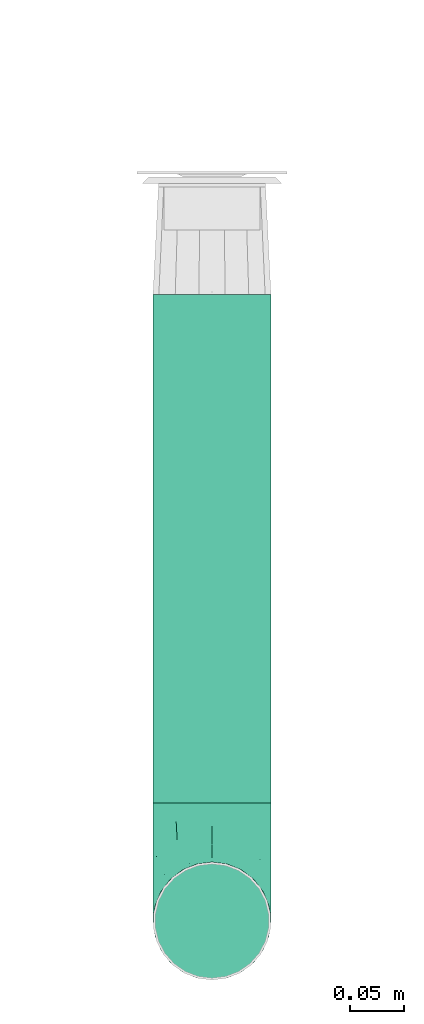
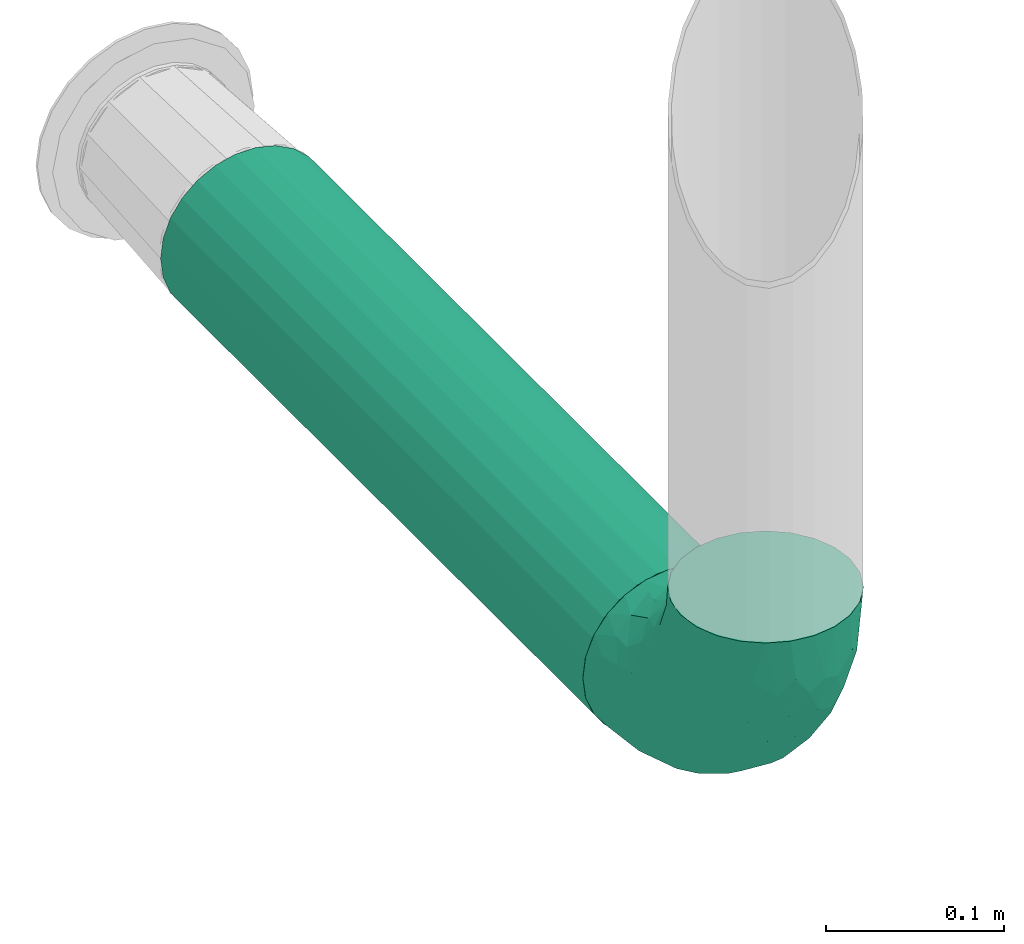
# One storey, part 69 of 115: 1 flow fitting, 1 flow segment.
"""IFC2X3 building model written with IfcOpenShell, lengths in millimetres."""

from ifc_helpers import new_model, entity, si_unit, converted_unit, derived_unit, direction, frame, origin_with_axes, origin_2d_with_axis, place, context, subcontext, project, spatial, hollow_circle, extrude, open_shell, surface_model, source, transform, mapped, material, layer, layer_set, layer_usage, type_object, element, save


model = new_model("IFC2X3")

# Units and contexts
model_context = context("Model", 3, precision=1e-05, world=origin_with_axes(), true_north=direction((0.0, 1.0)))
body_context = subcontext(model_context, "Body", "Model", "MODEL_VIEW")
ifc_project = project(units=[si_unit("AREAUNIT", "SQUARE_METRE"), si_unit("VOLUMEUNIT", "CUBIC_METRE", prefix="DECI"), si_unit("TIMEUNIT", "SECOND"), si_unit("THERMODYNAMICTEMPERATUREUNIT", "DEGREE_CELSIUS"), si_unit("PRESSUREUNIT", "PASCAL"), si_unit("MASSUNIT", "GRAM", prefix="KILO"), si_unit("LENGTHUNIT", "METRE", prefix="MILLI"), si_unit("POWERUNIT", "WATT"), si_unit("ELECTRICCURRENTUNIT", "AMPERE"), si_unit("ELECTRICVOLTAGEUNIT", "VOLT"), derived_unit("VOLUMETRICFLOWRATEUNIT", [(si_unit("VOLUMEUNIT", "CUBIC_METRE", prefix="DECI"), 1), (si_unit("TIMEUNIT", "SECOND"), -1)]), derived_unit("LINEARVELOCITYUNIT", [(si_unit("LENGTHUNIT", "METRE"), 1), (si_unit("TIMEUNIT", "SECOND"), -1)]), derived_unit("MASSDENSITYUNIT", [(si_unit("MASSUNIT", "GRAM", prefix="KILO"), 1), (si_unit("VOLUMEUNIT", "CUBIC_METRE"), -1)]), converted_unit("PLANEANGLEUNIT", "DEGREE", entity("IfcRatioMeasure", 0.01745), si_unit("PLANEANGLEUNIT", "RADIAN"), dimensions=[0, 0, 0, 0, 0, 0, 0])], contexts=[model_context])

# Site, building, storey
site_placement = place(None, origin_with_axes())
site = spatial("IfcSite", under=ifc_project, at=site_placement, CompositionType="ELEMENT")
building_placement = place(site_placement, origin_with_axes())
building = spatial("IfcBuilding", under=site, at=building_placement, Name="mc-building", CompositionType="ELEMENT")
storey_placement = place(building_placement, frame((0.0, 0.0, 2950.0), z_axis=(0.0, 0.0, 1.0), x_axis=(1.0, 0.0, 0.0)))
storey = spatial("IfcBuildingStorey", under=building, at=storey_placement, Name="2. Korrus", CompositionType="ELEMENT", Elevation=2950.0)

# Flow fitting
duct_fitting_type = type_object("IfcDuctFittingType", Name="BU", PredefinedType="BEND")
shared_shape_1 = source(origin_with_axes(), body_context, "Body", "SurfaceModel", [
    surface_model("IfcShellBasedSurfaceModel", [(-110.0, 0.0, -55.0), (-110.0, -14.23505, -53.12592), (-110.0, 14.23505, -53.12592), (-110.0, 53.12592, 14.23505), (-110.0, 27.5, -47.63139), (-110.0, 38.89087, -38.89087), (-110.0, -55.0, 0.0), (-110.0, -53.12592, 14.23505), (-110.0, -38.89087, -38.89087), (-110.0, -27.5, -47.63139), (-110.0, -53.12592, -14.23505), (-110.0, -47.63139, -27.5), (-110.0, -14.23505, 53.12592), (-110.0, 14.23505, 53.12592), (-110.0, 27.5, 47.63139), (-110.0, -47.63139, 27.5), (-110.0, -38.89087, 38.89087), (-110.0, -27.5, 47.63139), (-110.0, 0.0, 55.0), (-110.0, 55.0, 0.0), (-110.0, 53.12592, -14.23505), (-110.0, 47.63139, -27.5), (-110.0, 47.63139, 27.5), (-110.0, 38.89087, 38.89087), (-14.23505, 110.0, -53.12592), (-55.0, 110.0, 0.0), (0.0, 110.0, -55.0), (-27.5, 110.0, -47.63139), (-38.89087, 110.0, -38.89087), (-47.63139, 110.0, -27.5), (38.89087, 110.0, -38.89087), (53.12592, 110.0, 14.23505), (27.5, 110.0, -47.63139), (14.23505, 110.0, -53.12592), (47.63139, 110.0, -27.5), (53.12592, 110.0, -14.23505), (55.0, 110.0, 0.0), (-53.12592, 110.0, -14.23505), (-53.12592, 110.0, 14.23505), (-47.63139, 110.0, 27.5), (-38.89087, 110.0, 38.89087), (-27.5, 110.0, 47.63139), (0.0, 110.0, 55.0), (-14.23505, 110.0, 53.12592), (38.89087, 110.0, 38.89087), (47.63139, 110.0, 27.5), (27.5, 110.0, 47.63139), (14.23505, 110.0, 53.12592), (-64.21732, 48.68956, 43.63444), (-76.6405, 38.18013, 45.55988), (-60.44912, 32.56953, 51.94617), (-76.00813, 5.38378, 55.0), (-90.15553, 11.94394, 54.09138), (-78.5998, 26.77405, 50.81338), (-70.18771, 18.55163, 54.03432), (-75.55424, 54.2118, 32.41257), (-93.27622, 45.77614, 33.48188), (-96.12334, 22.13664, 50.81337), (-21.00813, 45.34362, 55.0), (-18.36258, 70.48427, 54.04484), (-32.04182, 59.64019, 52.24446), (-63.88653, 74.77858, 17.99134), (-74.66383, 63.08407, 19.92123), (-63.60674, 66.07878, 29.97482), (-99.597, 52.72185, 18.52927), (-93.11138, 56.59448, 10.50359), (-98.21577, 57.34403, 0.0), (-53.42855, 92.60092, 21.04759), (-88.54852, 54.8376, 21.04759), (-11.86161, 90.23965, 54.10313), (-5.38378, 76.00813, 55.0), (-57.34403, 98.21577, 0.0), (-56.64619, 93.12774, 10.22088), (-45.34362, 21.00813, 55.0), (-44.60838, 44.60838, 52.13415), (-92.68484, 35.46673, 43.63443), (-22.25266, 95.40765, 50.81337), (-35.97783, 90.61597, 43.63443), (-43.70931, 69.58671, 44.47149), (-27.23711, 77.39884, 50.81337), (-57.2828, 79.3123, 24.9774), (-58.67786, 84.31125, 16.04456), (-82.93277, 60.36161, 12.91784), (-49.88337, 54.51816, 47.224), (-74.57753, 66.83759, 9.55742), (-45.35812, 94.97281, 33.48188), (-59.18663, 88.95241, 0.0), (-51.517, 78.6292, 33.48188), (-65.14788, 80.03077, 0.0), (-56.45322, 62.06476, 39.63545), (-88.95241, 59.18663, 0.0), (-71.10913, 71.10913, 0.0), (-80.03077, 65.14788, 0.0), (-94.9309, 45.36788, -33.48188), (-93.11358, 56.60141, -10.46614), (-99.64997, 52.79499, -18.30015), (-90.20425, 36.08686, -43.63443), (-79.99933, 46.56772, -37.92748), (-76.00813, 5.38378, -55.0), (-72.75364, 19.68651, -53.60527), (-45.34362, 21.00813, -55.0), (-21.91957, 65.12078, -53.85897), (-5.38378, 76.00813, -55.0), (-21.00813, 45.34362, -55.0), (-35.41876, 92.89265, -43.63443), (-91.10309, 11.02766, -54.21832), (-45.77614, 93.27622, -33.48188), (-90.50474, 23.21022, -50.81337), (-70.92854, 33.31794, -49.51754), (-78.52933, 63.35627, -11.73997), (-24.91508, 84.05606, -50.81337), (-88.78941, 54.74452, -21.04759), (-69.59921, 57.34866, -33.48187), (-73.36422, 62.46673, -22.94182), (-63.49062, 67.59111, -28.46929), (-56.59448, 93.11138, -10.50359), (-54.8376, 88.54852, -21.04759), (-54.10679, 75.85581, -32.31867), (-57.75956, 31.09612, -52.80882), (-52.72185, 99.597, -18.52927), (-12.62913, 89.46304, -53.99097), (-34.46825, 66.46123, -50.04329), (-43.9837, 43.9837, -52.42279), (-65.78527, 72.58348, -17.68796), (-70.34468, 43.65295, -44.21951), (-57.47001, 51.99467, -44.91465), (-60.72547, 82.29174, -12.88567), (-42.34915, 74.24548, -43.63444), (-57.25194, 63.5016, -38.08211), (-80.95344, 53.56991, -29.32027), (-52.32891, 4.55257, -54.0482), (32.52942, 47.13398, -30.48571), (14.88266, 20.92917, -33.7947), (14.95561, 36.05775, -42.26543), (30.24048, 70.09027, -41.7461), (19.3559, 65.35825, -48.00507), (-70.35075, -46.44478, -19.5952), (-47.13398, -32.52942, -30.48571), (-28.49299, -30.5778, -16.4009), (-4.55257, 52.32891, -54.0482), (-22.4954, 22.4954, -53.25347), (-75.47368, -11.22546, -52.60718), (-81.32209, -51.5606, -9.98467), (-80.81763, -41.84862, -32.14655), (-70.09027, -30.24048, -41.7461), (-36.05774, -14.95561, -42.26543), (-9.15831, -10.852, -27.8997), (-65.35825, -19.3559, -48.00507), (11.22546, 75.47368, -52.60718), (3.94376, 43.9333, -50.53315), (-13.39742, 13.39743, -48.13058), (-43.9333, -3.94376, -50.53315), (49.37776, 67.29486, 0.0), (41.8609, 47.82256, -9.92641), (50.20582, 74.51695, -9.9731), (18.93131, 11.7156, -17.56239), (-27.5, -32.89419, 0.0), (-1.23348, -12.25375, -12.18106), (41.84862, 80.81763, -32.14655), (35.70604, 41.31408, -20.38235), (46.44478, 70.35075, -19.5952), (32.89419, 27.5, 0.0), (6.67262, -6.67262, 0.0), (-67.29486, -49.37776, 0.0), (-50.36265, -42.95545, -9.51562), (-5.47251, 5.47251, -39.92906), (-70.35075, -46.44478, 19.5952), (-74.51695, -50.20582, 9.9731), (-41.31407, -35.70604, 20.38235), (-47.13398, -32.52942, 30.48571), (-80.81763, -41.84862, 32.14655), (-4.55257, 52.32891, 54.0482), (11.22546, 75.47368, 52.60718), (-43.9333, -3.94376, 50.53315), (-65.35825, -19.3559, 48.00507), (-36.05774, -14.95561, 42.26543), (-70.09027, -30.24048, 41.7461), (-11.7156, -18.93131, 17.56239), (30.5778, 28.49299, 16.4009), (12.25375, 1.23348, 12.18106), (51.5606, 81.32209, 9.98467), (42.95545, 50.36265, 9.51562), (-75.47368, -11.22546, 52.60718), (-52.32891, 4.55257, 54.0482), (3.94376, 43.9333, 50.53315), (-22.4954, 22.4954, 53.25347), (-13.39742, 13.39743, 48.13058), (10.852, 9.15831, 27.8997), (-20.92916, -14.88266, 33.79469), (-47.82256, -41.8609, 9.92641), (32.52942, 47.13398, 30.48571), (46.44478, 70.35075, 19.5952), (41.84862, 80.81763, 32.14655), (30.24048, 70.09027, 41.7461), (19.3559, 65.35825, 48.00507), (14.95561, 36.05775, 42.26543), (-5.47251, 5.47251, 39.92906)], [open_shell([[[0, 1, 2]], [[2, 3, 4]], [[4, 3, 5]], [[2, 6, 7]], [[8, 6, 9]], [[1, 9, 6]], [[10, 6, 11]], [[8, 11, 6]], [[6, 2, 1]], [[12, 13, 14]], [[15, 2, 7]], [[16, 17, 2]], [[2, 17, 12]], [[12, 18, 13]], [[19, 20, 3]], [[5, 3, 21]], [[20, 21, 3]], [[22, 3, 2]], [[23, 22, 2]], [[12, 14, 2]], [[2, 14, 23]], [[15, 16, 2]], [[24, 25, 26]], [[27, 25, 24]], [[25, 28, 29]], [[28, 25, 27]], [[30, 26, 31]], [[26, 30, 32]], [[32, 33, 26]], [[34, 31, 35]], [[31, 34, 30]], [[35, 31, 36]], [[29, 37, 25]], [[38, 39, 26]], [[39, 40, 26]], [[41, 42, 40]], [[42, 26, 40]], [[42, 41, 43]], [[26, 44, 45]], [[31, 26, 45]], [[26, 46, 44]], [[47, 46, 26]], [[42, 47, 26]], [[25, 38, 26]], [[48, 49, 50]], [[18, 51, 52]], [[53, 54, 50]], [[55, 56, 49]], [[56, 22, 23]], [[13, 57, 14]], [[58, 59, 60]], [[61, 62, 63]], [[3, 64, 65]], [[53, 52, 54]], [[3, 65, 66]], [[67, 39, 38]], [[56, 68, 64]], [[65, 64, 68]], [[69, 59, 70]], [[38, 71, 72]], [[73, 58, 74]], [[75, 49, 56]], [[76, 69, 43]], [[53, 57, 52]], [[77, 78, 79]], [[41, 76, 43]], [[43, 69, 42]], [[55, 68, 56]], [[23, 14, 75]], [[76, 77, 79]], [[80, 67, 81]], [[62, 82, 68]], [[60, 78, 83]], [[62, 84, 82]], [[85, 77, 40]], [[81, 67, 72]], [[86, 72, 71]], [[87, 85, 67]], [[61, 81, 88]], [[77, 41, 40]], [[78, 77, 87]], [[23, 75, 56]], [[83, 89, 48]], [[85, 40, 39]], [[62, 68, 55]], [[89, 87, 63]], [[83, 48, 50]], [[57, 75, 14]], [[49, 75, 53]], [[67, 85, 39]], [[87, 77, 85]], [[63, 62, 55]], [[89, 55, 48]], [[80, 63, 87]], [[66, 65, 90]], [[66, 19, 3]], [[84, 91, 92]], [[92, 90, 82]], [[65, 82, 90]], [[61, 84, 62]], [[92, 82, 84]], [[68, 82, 65]], [[3, 22, 64]], [[56, 64, 22]], [[38, 25, 71]], [[81, 72, 86]], [[38, 72, 67]], [[91, 61, 88]], [[80, 81, 61]], [[63, 80, 61]], [[67, 80, 87]], [[77, 76, 41]], [[79, 59, 69]], [[79, 69, 76]], [[42, 69, 70]], [[60, 59, 79]], [[58, 70, 59]], [[78, 60, 79]], [[58, 60, 74]], [[52, 57, 13]], [[75, 57, 53]], [[18, 52, 13]], [[52, 51, 54]], [[51, 73, 54]], [[50, 73, 74]], [[73, 50, 54]], [[50, 74, 83]], [[60, 83, 74]], [[89, 83, 78]], [[87, 89, 78]], [[55, 89, 63]], [[50, 49, 53]], [[55, 49, 48]], [[81, 86, 88]], [[91, 84, 61]], [[5, 21, 93]], [[90, 94, 66]], [[20, 94, 95]], [[96, 93, 97]], [[98, 99, 100]], [[96, 4, 5]], [[101, 102, 103]], [[28, 27, 104]], [[2, 105, 0]], [[104, 106, 28]], [[99, 105, 107]], [[108, 107, 96]], [[90, 109, 94]], [[107, 2, 4]], [[20, 66, 94]], [[27, 24, 110]], [[109, 111, 94]], [[112, 113, 114]], [[37, 115, 71]], [[116, 106, 117]], [[99, 118, 100]], [[116, 115, 119]], [[37, 119, 115]], [[24, 120, 110]], [[121, 110, 101]], [[119, 106, 116]], [[101, 110, 120]], [[122, 103, 100]], [[117, 123, 116]], [[124, 125, 108]], [[115, 116, 126]], [[106, 29, 28]], [[26, 102, 120]], [[127, 104, 110]], [[97, 124, 96]], [[125, 122, 118]], [[128, 127, 125]], [[96, 5, 93]], [[115, 126, 86]], [[117, 106, 127]], [[111, 113, 129]], [[95, 93, 21]], [[97, 129, 112]], [[110, 104, 27]], [[106, 104, 127]], [[96, 107, 4]], [[99, 107, 108]], [[99, 108, 118]], [[105, 99, 98]], [[112, 114, 128]], [[121, 125, 127]], [[20, 19, 66]], [[109, 90, 92]], [[94, 111, 95]], [[91, 123, 109]], [[129, 113, 112]], [[93, 95, 111]], [[21, 20, 95]], [[71, 115, 86]], [[71, 25, 37]], [[123, 91, 88]], [[126, 116, 123]], [[123, 88, 126]], [[86, 126, 88]], [[37, 29, 119]], [[106, 119, 29]], [[129, 93, 111]], [[124, 112, 125]], [[0, 105, 98]], [[107, 105, 2]], [[125, 118, 108]], [[100, 118, 122]], [[93, 129, 97]], [[113, 111, 109]], [[109, 123, 113]], [[114, 123, 117]], [[123, 114, 113]], [[128, 114, 117]], [[127, 128, 117]], [[112, 128, 125]], [[103, 122, 101]], [[110, 121, 127]], [[101, 122, 121]], [[125, 121, 122]], [[26, 120, 24]], [[101, 120, 102]], [[96, 124, 108]], [[92, 91, 109]], [[112, 124, 97]], [[100, 130, 98]], [[131, 132, 133]], [[32, 134, 135]], [[136, 137, 138]], [[139, 140, 103]], [[98, 141, 0]], [[142, 10, 136]], [[143, 144, 137]], [[6, 10, 142]], [[137, 145, 146]], [[144, 147, 145]], [[143, 136, 11]], [[11, 136, 10]], [[8, 143, 11]], [[148, 149, 139]], [[8, 9, 144]], [[9, 1, 147]], [[130, 141, 98]], [[103, 140, 100]], [[148, 135, 149]], [[150, 151, 140]], [[152, 153, 154]], [[130, 140, 151]], [[148, 26, 33]], [[147, 1, 141]], [[155, 146, 132]], [[156, 138, 157]], [[134, 30, 158]], [[150, 140, 149]], [[158, 30, 34]], [[30, 134, 32]], [[153, 159, 160]], [[131, 160, 159]], [[144, 145, 137]], [[36, 152, 154]], [[146, 138, 137]], [[155, 161, 162]], [[158, 160, 131]], [[133, 149, 135]], [[156, 163, 164]], [[163, 142, 164]], [[139, 103, 102]], [[153, 152, 161]], [[34, 35, 160]], [[162, 157, 155]], [[132, 165, 133]], [[157, 146, 155]], [[140, 130, 100]], [[141, 130, 151]], [[141, 151, 147]], [[141, 1, 0]], [[102, 26, 148]], [[140, 139, 149]], [[102, 148, 139]], [[135, 33, 32]], [[151, 150, 145]], [[9, 147, 144]], [[151, 145, 147]], [[145, 165, 146]], [[135, 148, 33]], [[133, 135, 134]], [[131, 133, 134]], [[133, 165, 150]], [[133, 150, 149]], [[145, 150, 165]], [[132, 131, 159]], [[146, 165, 132]], [[160, 158, 34]], [[134, 158, 131]], [[144, 143, 8]], [[136, 143, 137]], [[155, 153, 161]], [[154, 153, 160]], [[153, 155, 159]], [[132, 159, 155]], [[160, 35, 154]], [[36, 154, 35]], [[164, 136, 138]], [[6, 142, 163]], [[136, 164, 142]], [[156, 164, 138]], [[156, 157, 162]], [[146, 157, 138]], [[15, 7, 166]], [[6, 163, 167]], [[168, 169, 166]], [[166, 169, 170]], [[171, 172, 70]], [[173, 174, 175]], [[17, 176, 174]], [[177, 156, 162]], [[176, 16, 170]], [[170, 16, 15]], [[161, 178, 179]], [[152, 180, 181]], [[182, 173, 183]], [[18, 12, 182]], [[184, 185, 186]], [[183, 185, 73]], [[183, 73, 51]], [[177, 187, 188]], [[189, 168, 166]], [[187, 178, 190]], [[16, 176, 17]], [[161, 152, 181]], [[45, 191, 31]], [[45, 44, 192]], [[192, 191, 45]], [[180, 36, 31]], [[193, 194, 195]], [[46, 47, 194]], [[193, 195, 190]], [[193, 44, 46]], [[172, 42, 70]], [[185, 58, 73]], [[189, 163, 156]], [[163, 189, 167]], [[70, 58, 171]], [[184, 171, 185]], [[169, 188, 175]], [[180, 31, 191]], [[192, 193, 190]], [[191, 190, 178]], [[182, 174, 173]], [[194, 47, 172]], [[190, 195, 187]], [[186, 185, 173]], [[162, 179, 177]], [[188, 196, 175]], [[179, 187, 177]], [[185, 171, 58]], [[172, 171, 184]], [[172, 184, 194]], [[172, 47, 42]], [[51, 18, 182]], [[185, 183, 173]], [[51, 182, 183]], [[174, 12, 17]], [[184, 186, 195]], [[46, 194, 193]], [[184, 195, 194]], [[195, 196, 187]], [[174, 182, 12]], [[175, 174, 176]], [[169, 175, 176]], [[175, 196, 186]], [[175, 186, 173]], [[195, 186, 196]], [[188, 169, 168]], [[187, 196, 188]], [[166, 170, 15]], [[176, 170, 169]], [[193, 192, 44]], [[191, 192, 190]], [[177, 189, 156]], [[167, 189, 166]], [[189, 177, 168]], [[188, 168, 177]], [[166, 7, 167]], [[6, 167, 7]], [[181, 191, 178]], [[36, 180, 152]], [[191, 181, 180]], [[161, 181, 178]], [[161, 179, 162]], [[187, 179, 178]]])]),
])
flow_fitting_placement = place(storey_placement, frame((33752.94253, -687.64676, 2300.0), z_axis=(-1.0, 0.0, 0.0), x_axis=(0.0, -1.0, 0.0)))
element("IfcFlowFitting", 1, at=flow_fitting_placement, inside=storey, type_object=duct_fitting_type, Name="BU", context=body_context, shape_type="MappedRepresentation", body=[
    mapped(shared_shape_1, transform((0.0, 0.0, 0.0), scale=1.0)),
])

# Flow segment
ifc_material = material(Name="FZ1")
ifc_layer = layer(ifc_material, 0.0)
ifc_layer_set = layer_set([ifc_layer], Name="FZ1")
ifc_layer_usage = layer_usage(ifc_layer_set, "AXIS1", "POSITIVE", 0.0)
duct_segment_type = type_object("IfcDuctSegmentType", PredefinedType="RIGIDSEGMENT")
shared_shape_2 = source(origin_with_axes(), body_context, "Body", "SweptSolid", [
    extrude(hollow_circle(Radius=55.0, WallThickness=2.0, at=origin_2d_with_axis()), frame((0.0, 0.0, 0.0), z_axis=(1.0, 0.0, 0.0), x_axis=(0.0, 1.0, 0.0)), (0.0, 0.0, 1.0), 474.5),
])
flow_segment_placement = place(storey_placement, frame((33752.94253, -103.1, 2300.0), z_axis=(0.0, 0.0, 1.0), x_axis=(0.0, -1.0, 0.0)))
element("IfcFlowSegment", 2, at=flow_segment_placement, inside=storey, type_object=duct_segment_type, material=ifc_layer_usage, context=body_context, shape_type="MappedRepresentation", body=[
    mapped(shared_shape_2, transform((0.0, 0.0, 0.0), scale=1.0)),
])

save(model, "model.ifc")
